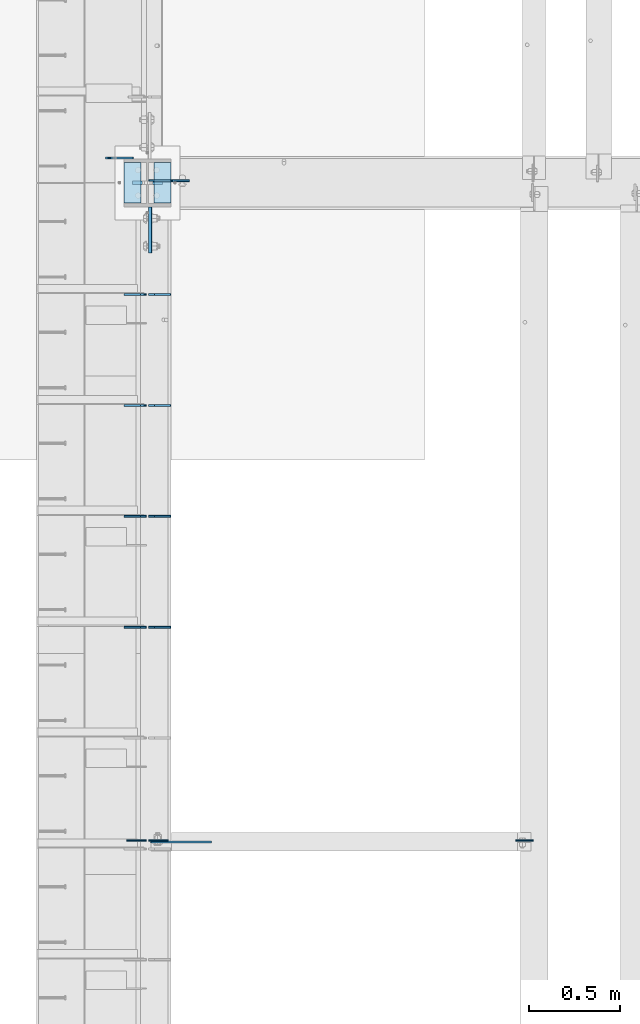
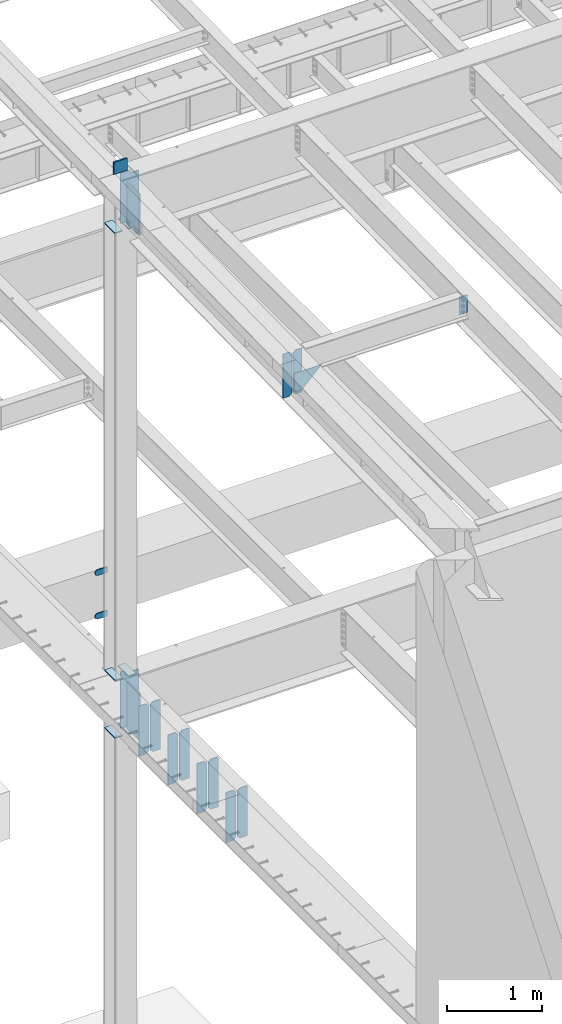
# One storey, part 1518 of 1763: 25 plates, 5 elements without a shape of their own.
"""IFC2X3 building model written with IfcOpenShell, lengths in millimetres."""

from ifc_helpers import new_model, si_unit, frame, origin_with_axes, place, context, subcontext, project, spatial, faceted_brep, material, type_object, element, aggregate, save


model = new_model("IFC2X3")

# Units and contexts
model_context = context("Model", 3, precision=1e-05, world=origin_with_axes())
body_context = subcontext(model_context, "Body", "Model", "MODEL_VIEW")
ifc_project = project(units=[si_unit("LENGTHUNIT", "METRE", prefix="MILLI"), si_unit("AREAUNIT", "SQUARE_METRE"), si_unit("VOLUMEUNIT", "CUBIC_METRE"), si_unit("MASSUNIT", "GRAM", prefix="KILO"), si_unit("TIMEUNIT", "SECOND"), si_unit("PLANEANGLEUNIT", "RADIAN"), si_unit("SOLIDANGLEUNIT", "STERADIAN"), si_unit("THERMODYNAMICTEMPERATUREUNIT", "DEGREE_CELSIUS"), si_unit("LUMINOUSINTENSITYUNIT", "LUMEN")], contexts=[model_context])

# Site, building, storey
site_placement = place(None, origin_with_axes())
site = spatial("IfcSite", under=ifc_project, at=site_placement, CompositionType="ELEMENT")
building_placement = place(site_placement, origin_with_axes())
building = spatial("IfcBuilding", under=site, at=building_placement, Name="Undefined", CompositionType="ELEMENT")
storey_placement = place(building_placement, origin_with_axes())
storey = spatial("IfcBuildingStorey", under=building, at=storey_placement, Name="Undefined", CompositionType="ELEMENT", Elevation=0.0)

# Assembly, plates
assembly_1_placement = place(storey_placement, origin_with_axes())
assembly_1 = element("IfcElementAssembly", 1, at=assembly_1_placement, inside=storey, Name="COLUMN", AssemblyPlace="NOTDEFINED", PredefinedType="RIGID_FRAME")
ifc_material_1 = material(Name="STEEL/A36")
plate_type_1 = type_object("IfcPlateType", PredefinedType="NOTDEFINED")
plate_1_placement = place(assembly_1_placement, frame((-87453.2247736983, 44942.125, 6489.69999847412), z_axis=(0.0, 0.0, -1.0), x_axis=(-1.0, 0.0, 0.0)))
plate_1 = element("IfcPlate", 2, at=plate_1_placement, type_object=plate_type_1, material=ifc_material_1, Name="PLATE", context=body_context, shape_type="Brep", body=[
    faceted_brep([(0.0, -4.76249999999982, 0.0), (0.0, -4.76250000000073, 76.1999969482422), (0.0, 4.76250000000073, 76.1999969482422), (0.0, 4.76249999999982, 0.0), (114.299995422363, -4.76250000000073, 76.1999969482422), (114.299995422363, 4.76250000000073, 76.1999969482422), (126.073542436527, -4.76250000000073, 74.3352502937696), (126.073542436527, 4.76250000000073, 74.3352502937696), (136.694612637817, -4.76250000000073, 68.923544725345), (136.694612637817, 4.76250000000073, 68.923544725345), (145.123541673587, -4.76250000000073, 60.4946156895749), (145.123541673587, 4.76250000000073, 60.4946156895749), (150.535247242013, -4.76250000000073, 49.8735454882844), (150.535247242013, 4.76250000000073, 49.8735454882844), (152.399993896484, -4.76250000000073, 38.0999984741211), (152.399993896484, 4.76250000000073, 38.0999984741211), (150.535247242013, -4.76250000000073, 26.3264514599578), (150.535247242013, 4.76250000000073, 26.3264514599578), (145.123541673587, -4.76250000000073, 15.7053812586673), (145.123541673587, 4.76250000000073, 15.7053812586673), (136.694612637817, -4.76250000000073, 7.27645222289721), (136.694612637817, 4.76250000000073, 7.27645222289721), (126.073542436527, -4.76250000000073, 1.86474665447258), (126.073542436527, 4.76250000000073, 1.86474665447258), (114.299995422363, -4.76250000000073, 0.0), (114.299995422363, 4.76250000000073, 0.0)], [[[0, 1, 2, 3]], [[1, 4, 5, 2]], [[4, 6, 7, 5]], [[6, 8, 9, 7]], [[8, 10, 11, 9]], [[10, 12, 13, 11]], [[12, 14, 15, 13]], [[14, 16, 17, 15]], [[16, 18, 19, 17]], [[18, 20, 21, 19]], [[20, 22, 23, 21]], [[22, 24, 25, 23]], [[24, 0, 3, 25]], [[5, 7, 9, 11, 13, 15, 17, 19, 21, 23, 25, 3, 2]], [[24, 22, 20, 18, 16, 14, 12, 10, 8, 6, 4, 1, 0]]]),
])
plate_2_placement = place(assembly_1_placement, frame((-87453.2247736983, 44942.125, 5930.89999847412), z_axis=(0.0, 0.0, -1.0), x_axis=(-1.0, 0.0, 0.0)))
plate_2 = element("IfcPlate", 3, at=plate_2_placement, type_object=plate_type_1, material=ifc_material_1, Name="PLATE", context=body_context, shape_type="Brep", body=[
    faceted_brep([(0.0, -4.76249999999982, 0.0), (0.0, -4.76250000000073, 76.1999969482422), (0.0, 4.76250000000073, 76.1999969482422), (0.0, 4.76249999999982, 0.0), (114.299995422363, -4.76250000000073, 76.1999969482422), (114.299995422363, 4.76250000000073, 76.1999969482422), (126.073542436527, -4.76250000000073, 74.3352502937696), (126.073542436527, 4.76250000000073, 74.3352502937696), (136.694612637817, -4.76250000000073, 68.923544725345), (136.694612637817, 4.76250000000073, 68.923544725345), (145.123541673587, -4.76250000000073, 60.4946156895749), (145.123541673587, 4.76250000000073, 60.4946156895749), (150.535247242013, -4.76250000000073, 49.8735454882844), (150.535247242013, 4.76250000000073, 49.8735454882844), (152.399993896484, -4.76250000000073, 38.0999984741211), (152.399993896484, 4.76250000000073, 38.0999984741211), (150.535247242013, -4.76250000000073, 26.3264514599578), (150.535247242013, 4.76250000000073, 26.3264514599578), (145.123541673587, -4.76250000000073, 15.7053812586673), (145.123541673587, 4.76250000000073, 15.7053812586673), (136.694612637817, -4.76250000000073, 7.27645222289721), (136.694612637817, 4.76250000000073, 7.27645222289721), (126.073542436527, -4.76250000000073, 1.86474665447258), (126.073542436527, 4.76250000000073, 1.86474665447258), (114.299995422363, -4.76250000000073, 0.0), (114.299995422363, 4.76250000000073, 0.0)], [[[0, 1, 2, 3]], [[1, 4, 5, 2]], [[4, 6, 7, 5]], [[6, 8, 9, 7]], [[8, 10, 11, 9]], [[10, 12, 13, 11]], [[12, 14, 15, 13]], [[14, 16, 17, 15]], [[16, 18, 19, 17]], [[18, 20, 21, 19]], [[20, 22, 23, 21]], [[22, 24, 25, 23]], [[24, 0, 3, 25]], [[5, 7, 9, 11, 13, 15, 17, 19, 21, 23, 25, 3, 2]], [[24, 22, 20, 18, 16, 14, 12, 10, 8, 6, 4, 1, 0]]]),
])

assembly_2_placement = place(storey_placement, origin_with_axes())
assembly_2 = element("IfcElementAssembly", 4, at=assembly_2_placement, inside=storey, Name="BEAM", AssemblyPlace="NOTDEFINED", PredefinedType="RIGID_FRAME")
plate_type_2 = type_object("IfcPlateType", PredefinedType="NOTDEFINED")
plate_3_placement = place(assembly_2_placement, frame((-87246.8497736984, 42362.4375, 4525.9625), z_axis=(0.0, 0.0, 1.0), x_axis=(-1.0, 0.0, 0.0)))
plate_3 = element("IfcPlate", 5, at=plate_3_placement, type_object=plate_type_2, material=ifc_material_1, Name="PLATE", context=body_context, shape_type="Brep", body=[
    faceted_brep([(0.0, -4.76249999999982, 0.0), (0.0, -4.76250000000073, 644.525024414062), (0.0, 4.76250000000073, 644.525024414062), (0.0, 4.76249999999982, 0.0), (89.6937484741211, -4.76250000000073, 644.525024414062), (89.6937484741211, 4.76250000000073, 644.525024414062), (121.443748474121, -4.76250000000073, 612.775024414062), (121.443748474121, 4.76250000000073, 612.775024414062), (121.443748474121, -4.76250000000073, 31.75), (121.443748474121, 4.76250000000073, 31.75), (89.6937484741211, -4.76249999999709, 0.0), (89.6937484741211, 4.76249999999709, 0.0)], [[[0, 1, 2, 3]], [[1, 4, 5, 2]], [[4, 6, 7, 5]], [[6, 8, 9, 7]], [[8, 10, 11, 9]], [[10, 0, 3, 11]], [[5, 7, 9, 11, 3, 2]], [[10, 8, 6, 4, 1, 0]]]),
])
plate_4_placement = place(assembly_2_placement, frame((-87382.5810236984, 42362.4375, 4525.9625), z_axis=(0.0, 0.0, 1.0), x_axis=(-1.0, 0.0, 0.0)))
plate_4 = element("IfcPlate", 6, at=plate_4_placement, type_object=plate_type_2, material=ifc_material_1, Name="PLATE", context=body_context, shape_type="Brep", body=[
    faceted_brep([(0.0, -4.76250000000073, 31.75), (0.0, -4.76250000000073, 612.775024414062), (0.0, 4.76250000000073, 612.775024414062), (0.0, 4.76250000000073, 31.75), (31.75, -4.76250000000073, 644.525024414062), (31.75, 4.76250000000073, 644.525024414062), (121.443748474121, -4.76250000000073, 644.525024414062), (121.443748474121, 4.76250000000073, 644.525024414062), (121.443748474121, -4.76250000000073, 0.0), (121.443748474121, 4.76250000000073, 0.0), (31.75, -4.76250000000073, 0.0), (31.75, 4.76250000000073, 0.0)], [[[0, 1, 2, 3]], [[1, 4, 5, 2]], [[4, 6, 7, 5]], [[6, 8, 9, 7]], [[8, 10, 11, 9]], [[10, 0, 3, 11]], [[5, 7, 9, 11, 3, 2]], [[10, 8, 6, 4, 1, 0]]]),
])
plate_5_placement = place(assembly_2_placement, frame((-87246.8497736984, 42972.0375, 4525.9625), z_axis=(0.0, 0.0, 1.0), x_axis=(-1.0, 0.0, 0.0)))
plate_5 = element("IfcPlate", 7, at=plate_5_placement, type_object=plate_type_2, material=ifc_material_1, Name="PLATE", context=body_context, shape_type="Brep", body=[
    faceted_brep([(0.0, -4.76249999999982, 0.0), (0.0, -4.76250000000073, 644.525024414062), (0.0, 4.76250000000073, 644.525024414062), (0.0, 4.76249999999982, 0.0), (89.6937484741211, -4.76250000000073, 644.525024414062), (89.6937484741211, 4.76250000000073, 644.525024414062), (121.443748474121, -4.76250000000073, 612.775024414062), (121.443748474121, 4.76250000000073, 612.775024414062), (121.443748474121, -4.76250000000073, 31.75), (121.443748474121, 4.76250000000073, 31.75), (89.6937484741211, -4.76249999999709, 0.0), (89.6937484741211, 4.76249999999709, 0.0)], [[[0, 1, 2, 3]], [[1, 4, 5, 2]], [[4, 6, 7, 5]], [[6, 8, 9, 7]], [[8, 10, 11, 9]], [[10, 0, 3, 11]], [[5, 7, 9, 11, 3, 2]], [[10, 8, 6, 4, 1, 0]]]),
])
plate_6_placement = place(assembly_2_placement, frame((-87382.5810236984, 42972.0375, 4525.9625), z_axis=(0.0, 0.0, 1.0), x_axis=(-1.0, 0.0, 0.0)))
plate_6 = element("IfcPlate", 8, at=plate_6_placement, type_object=plate_type_2, material=ifc_material_1, Name="PLATE", context=body_context, shape_type="Brep", body=[
    faceted_brep([(0.0, -4.76250000000073, 31.75), (0.0, -4.76250000000073, 612.775024414062), (0.0, 4.76250000000073, 612.775024414062), (0.0, 4.76250000000073, 31.75), (31.75, -4.76250000000073, 644.525024414062), (31.75, 4.76250000000073, 644.525024414062), (121.443748474121, -4.76250000000073, 644.525024414062), (121.443748474121, 4.76250000000073, 644.525024414062), (121.443748474121, -4.76250000000073, 0.0), (121.443748474121, 4.76250000000073, 0.0), (31.75, -4.76250000000073, 0.0), (31.75, 4.76250000000073, 0.0)], [[[0, 1, 2, 3]], [[1, 4, 5, 2]], [[4, 6, 7, 5]], [[6, 8, 9, 7]], [[8, 10, 11, 9]], [[10, 0, 3, 11]], [[5, 7, 9, 11, 3, 2]], [[10, 8, 6, 4, 1, 0]]]),
])
plate_7_placement = place(assembly_2_placement, frame((-87246.8497736984, 43581.6375, 4525.9625), z_axis=(0.0, 0.0, 1.0), x_axis=(-1.0, 0.0, 0.0)))
plate_7 = element("IfcPlate", 9, at=plate_7_placement, type_object=plate_type_2, material=ifc_material_1, Name="PLATE", context=body_context, shape_type="Brep", body=[
    faceted_brep([(0.0, -4.76249999999982, 0.0), (0.0, -4.76250000000073, 644.525024414062), (0.0, 4.76250000000073, 644.525024414062), (0.0, 4.76249999999982, 0.0), (89.6937484741211, -4.76250000000073, 644.525024414062), (89.6937484741211, 4.76250000000073, 644.525024414062), (121.443748474121, -4.76250000000073, 612.775024414062), (121.443748474121, 4.76250000000073, 612.775024414062), (121.443748474121, -4.76250000000073, 31.75), (121.443748474121, 4.76250000000073, 31.75), (89.6937484741211, -4.76249999999709, 0.0), (89.6937484741211, 4.76249999999709, 0.0)], [[[0, 1, 2, 3]], [[1, 4, 5, 2]], [[4, 6, 7, 5]], [[6, 8, 9, 7]], [[8, 10, 11, 9]], [[10, 0, 3, 11]], [[5, 7, 9, 11, 3, 2]], [[10, 8, 6, 4, 1, 0]]]),
])
plate_8_placement = place(assembly_2_placement, frame((-87382.5810236984, 43581.6375, 4525.9625), z_axis=(0.0, 0.0, 1.0), x_axis=(-1.0, 0.0, 0.0)))
plate_8 = element("IfcPlate", 10, at=plate_8_placement, type_object=plate_type_2, material=ifc_material_1, Name="PLATE", context=body_context, shape_type="Brep", body=[
    faceted_brep([(0.0, -4.76250000000073, 31.75), (0.0, -4.76250000000073, 612.775024414062), (0.0, 4.76250000000073, 612.775024414062), (0.0, 4.76250000000073, 31.75), (31.75, -4.76250000000073, 644.525024414062), (31.75, 4.76250000000073, 644.525024414062), (121.443748474121, -4.76250000000073, 644.525024414062), (121.443748474121, 4.76250000000073, 644.525024414062), (121.443748474121, -4.76250000000073, 0.0), (121.443748474121, 4.76250000000073, 0.0), (31.75, -4.76250000000073, 0.0), (31.75, 4.76250000000073, 0.0)], [[[0, 1, 2, 3]], [[1, 4, 5, 2]], [[4, 6, 7, 5]], [[6, 8, 9, 7]], [[8, 10, 11, 9]], [[10, 0, 3, 11]], [[5, 7, 9, 11, 3, 2]], [[10, 8, 6, 4, 1, 0]]]),
])
plate_9_placement = place(assembly_2_placement, frame((-87246.8497736984, 44191.2375, 4525.9625), z_axis=(0.0, 0.0, 1.0), x_axis=(-1.0, 0.0, 0.0)))
plate_9 = element("IfcPlate", 11, at=plate_9_placement, type_object=plate_type_2, material=ifc_material_1, Name="PLATE", context=body_context, shape_type="Brep", body=[
    faceted_brep([(0.0, -4.76249999999982, 0.0), (0.0, -4.76250000000073, 644.525024414062), (0.0, 4.76250000000073, 644.525024414062), (0.0, 4.76249999999982, 0.0), (89.6937484741211, -4.76250000000073, 644.525024414062), (89.6937484741211, 4.76250000000073, 644.525024414062), (121.443748474121, -4.76250000000073, 612.775024414062), (121.443748474121, 4.76250000000073, 612.775024414062), (121.443748474121, -4.76250000000073, 31.75), (121.443748474121, 4.76250000000073, 31.75), (89.6937484741211, -4.76249999999709, 0.0), (89.6937484741211, 4.76249999999709, 0.0)], [[[0, 1, 2, 3]], [[1, 4, 5, 2]], [[4, 6, 7, 5]], [[6, 8, 9, 7]], [[8, 10, 11, 9]], [[10, 0, 3, 11]], [[5, 7, 9, 11, 3, 2]], [[10, 8, 6, 4, 1, 0]]]),
])
plate_10_placement = place(assembly_2_placement, frame((-87382.5810236984, 44191.2375, 4525.9625), z_axis=(0.0, 0.0, 1.0), x_axis=(-1.0, 0.0, 0.0)))
plate_10 = element("IfcPlate", 12, at=plate_10_placement, type_object=plate_type_2, material=ifc_material_1, Name="PLATE", context=body_context, shape_type="Brep", body=[
    faceted_brep([(0.0, -4.76250000000073, 31.75), (0.0, -4.76250000000073, 612.775024414062), (0.0, 4.76250000000073, 612.775024414062), (0.0, 4.76250000000073, 31.75), (31.75, -4.76250000000073, 644.525024414062), (31.75, 4.76250000000073, 644.525024414062), (121.443748474121, -4.76250000000073, 644.525024414062), (121.443748474121, 4.76250000000073, 644.525024414062), (121.443748474121, -4.76250000000073, 0.0), (121.443748474121, 4.76250000000073, 0.0), (31.75, -4.76250000000073, 0.0), (31.75, 4.76250000000073, 0.0)], [[[0, 1, 2, 3]], [[1, 4, 5, 2]], [[4, 6, 7, 5]], [[6, 8, 9, 7]], [[8, 10, 11, 9]], [[10, 0, 3, 11]], [[5, 7, 9, 11, 3, 2]], [[10, 8, 6, 4, 1, 0]]]),
])
aggregate(assembly_2, [plate_3, plate_4, plate_5, plate_6, plate_7, plate_8, plate_9, plate_10])

# Plate
ifc_material_2 = material(Name="STEEL/A572-50")
plate_type_3 = type_object("IfcPlateType", PredefinedType="NOTDEFINED")
plate_11_placement = place(assembly_1_placement, frame((-87292.8872721725, 44805.5999999732, 11760.2588348652), z_axis=(0.0, 0.0, -1.0), x_axis=(-1.0, 0.0, 0.0)))
plate_11 = element("IfcPlate", 13, at=plate_11_placement, type_object=plate_type_3, material=ifc_material_2, Name="PLATE", context=body_context, shape_type="Brep", body=[
    faceted_brep([(7.27595761418343e-12, 9.52500000000146, 155.574990844727), (-1.45519152283669e-11, 7.27595761418343e-12, 165.099990844727), (165.099990844727, 0.0, 165.099990844727), (165.099990844727, 9.52500000000146, 155.574990844727), (-3.63797880709171e-11, -9.5249999999869, 155.574990844727), (165.099990844727, -9.52500000000146, 155.574990844727), (0.0, 9.52500000000146, 0.0), (0.0, -9.52500000000146, 0.0), (165.099990844727, -9.52500000000146, 0.0), (165.099990844727, 9.52500000000146, 0.0)], [[[0, 1, 2, 3]], [[1, 4, 5, 2]], [[6, 7, 4, 1, 0]], [[5, 8, 9, 3, 2]], [[8, 7, 6, 9]], [[9, 6, 0, 3]], [[7, 8, 5, 4]]]),
])

plate_type_4 = type_object("IfcPlateType", PredefinedType="NOTDEFINED")
plate_12_placement = place(assembly_1_placement, frame((-87410.3622736983, 44694.475, 4451.34997558594), z_axis=(0.0, 1.0, 0.0), x_axis=(-1.0, 0.0, 0.0)))
plate_12 = element("IfcPlate", 14, at=plate_12_placement, type_object=plate_type_4, material=ifc_material_1, Name="PLATE", context=body_context, shape_type="Brep", body=[
    faceted_brep([(0.0, -6.34999999999491, 1.45519152283669e-11), (0.0, -6.35000000000036, 222.25), (0.0, 6.35000000000036, 222.25), (0.0, 6.34999999999491, -2.91038304567337e-11), (93.6624984741211, -6.35000000000036, 222.25), (93.6624984741211, 6.35000000000036, 222.25), (93.6624984741211, -6.35000000000036, 0.0), (93.6624984741211, 6.35000000000036, 0.0)], [[[0, 1, 2, 3]], [[1, 4, 5, 2]], [[4, 6, 7, 5]], [[6, 0, 3, 7]], [[5, 7, 3, 2]], [[6, 4, 1, 0]]]),
])

plate_13_placement = place(assembly_1_placement, frame((-87410.3622736983, 44694.475, 5187.95), z_axis=(0.0, 1.0, 0.0), x_axis=(-1.0, 0.0, 0.0)))
plate_13 = element("IfcPlate", 15, at=plate_13_placement, type_object=plate_type_4, material=ifc_material_1, Name="PLATE", context=body_context, shape_type="Brep", body=[
    faceted_brep([(0.0, -6.34999999999491, 1.45519152283669e-11), (0.0, -6.35000000000036, 222.25), (0.0, 6.35000000000036, 222.25), (0.0, 6.34999999999491, -2.91038304567337e-11), (93.6624984741211, -6.35000000000036, 222.25), (93.6624984741211, 6.35000000000036, 222.25), (93.6624984741211, -6.35000000000036, 0.0), (93.6624984741211, 6.35000000000036, 0.0)], [[[0, 1, 2, 3]], [[1, 4, 5, 2]], [[4, 6, 7, 5]], [[6, 0, 3, 7]], [[5, 7, 3, 2]], [[6, 4, 1, 0]]]),
])

plate_14_placement = place(assembly_1_placement, frame((-87410.3622736983, 44694.475, 10928.4088287617), z_axis=(0.0, 1.0, 0.0), x_axis=(-1.0, 0.0, 0.0)))
plate_14 = element("IfcPlate", 16, at=plate_14_placement, type_object=plate_type_4, material=ifc_material_1, Name="PLATE", context=body_context, shape_type="Brep", body=[
    faceted_brep([(0.0, -6.34999999999491, 1.45519152283669e-11), (0.0, -6.35000000000036, 222.25), (0.0, 6.35000000000036, 222.25), (0.0, 6.34999999999491, -2.91038304567337e-11), (93.6624984741211, -6.35000000000036, 222.25), (93.6624984741211, 6.35000000000036, 222.25), (93.6624984741211, -6.35000000000036, 0.0), (93.6624984741211, 6.35000000000036, 0.0)], [[[0, 1, 2, 3]], [[1, 4, 5, 2]], [[4, 6, 7, 5]], [[6, 0, 3, 7]], [[5, 7, 3, 2]], [[6, 4, 1, 0]]]),
])

plate_15_placement = place(assembly_1_placement, frame((-87246.8497736983, 44694.475, 10928.4088287617), z_axis=(0.0, 1.0, 0.0), x_axis=(-1.0, 0.0, 0.0)))
plate_15 = element("IfcPlate", 17, at=plate_15_placement, type_object=plate_type_4, material=ifc_material_1, Name="PLATE", context=body_context, shape_type="Brep", body=[
    faceted_brep([(0.0, -6.34999999999491, 1.45519152283669e-11), (0.0, -6.35000000000036, 222.25), (0.0, 6.35000000000036, 222.25), (0.0, 6.34999999999491, -2.91038304567337e-11), (93.6624984741211, -6.35000000000036, 222.25), (93.6624984741211, 6.35000000000036, 222.25), (93.6624984741211, -6.35000000000036, 0.0), (93.6624984741211, 6.35000000000036, 0.0)], [[[0, 1, 2, 3]], [[1, 4, 5, 2]], [[4, 6, 7, 5]], [[6, 0, 3, 7]], [[5, 7, 3, 2]], [[6, 4, 1, 0]]]),
])

plate_16_placement = place(assembly_1_placement, frame((-87246.8497736983, 44694.475, 4451.34997558594), z_axis=(0.0, 1.0, 0.0), x_axis=(-1.0, 0.0, 0.0)))
plate_16 = element("IfcPlate", 18, at=plate_16_placement, type_object=plate_type_4, material=ifc_material_1, Name="PLATE", context=body_context, shape_type="Brep", body=[
    faceted_brep([(0.0, -6.34999999999491, 1.45519152283669e-11), (0.0, -6.35000000000036, 222.25), (0.0, 6.35000000000036, 222.25), (0.0, 6.34999999999491, -2.91038304567337e-11), (93.6624984741211, -6.35000000000036, 222.25), (93.6624984741211, 6.35000000000036, 222.25), (93.6624984741211, -6.35000000000036, 0.0), (93.6624984741211, 6.35000000000036, 0.0)], [[[0, 1, 2, 3]], [[1, 4, 5, 2]], [[4, 6, 7, 5]], [[6, 0, 3, 7]], [[5, 7, 3, 2]], [[6, 4, 1, 0]]]),
])

plate_17_placement = place(assembly_1_placement, frame((-87246.8497736983, 44694.475, 5187.95), z_axis=(0.0, 1.0, 0.0), x_axis=(-1.0, 0.0, 0.0)))
plate_17 = element("IfcPlate", 19, at=plate_17_placement, type_object=plate_type_4, material=ifc_material_1, Name="PLATE", context=body_context, shape_type="Brep", body=[
    faceted_brep([(0.0, -6.34999999999491, 1.45519152283669e-11), (0.0, -6.35000000000036, 222.25), (0.0, 6.35000000000036, 222.25), (0.0, 6.34999999999491, -2.91038304567337e-11), (93.6624984741211, -6.35000000000036, 222.25), (93.6624984741211, 6.35000000000036, 222.25), (93.6624984741211, -6.35000000000036, 0.0), (93.6624984741211, 6.35000000000036, 0.0)], [[[0, 1, 2, 3]], [[1, 4, 5, 2]], [[4, 6, 7, 5]], [[6, 0, 3, 7]], [[5, 7, 3, 2]], [[6, 4, 1, 0]]]),
])

# Assembly, plate
assembly_3_placement = place(storey_placement, origin_with_axes())
assembly_3 = element("IfcElementAssembly", 20, at=assembly_3_placement, inside=storey, Name="BEAM", AssemblyPlace="NOTDEFINED", PredefinedType="RIGID_FRAME")
plate_type_5 = type_object("IfcPlateType", PredefinedType="NOTDEFINED")
plate_18_placement = place(assembly_3_placement, frame((-85253.0631665555, 41189.2749999833, 11483.0991337623), z_axis=(-1.0, 0.0, 0.0), x_axis=(0.0, 0.0, -1.0)))
plate_18 = element("IfcPlate", 21, at=plate_18_placement, type_object=plate_type_5, material=ifc_material_1, Name="PLATE", context=body_context, shape_type="Brep", body=[
    faceted_brep([(1.81898940354586e-12, -3.17500000000291, 0.0), (-2.52839527092874e-10, -3.17500000000001, 98.4250000002357), (4.17785486206412e-08, 3.17500000000001, 98.425000000243), (-1.81898940354586e-12, 3.17499999997381, 0.0), (228.600006103516, -3.17499999999927, 98.4250030517578), (228.600006103516, 3.17499999999927, 98.4250030517578), (228.600006103516, -3.17500000001019, -7.27595761418343e-12), (228.600006103516, 3.17499999999563, -7.27595761418343e-12)], [[[0, 1, 2, 3]], [[1, 4, 5, 2]], [[4, 6, 7, 5]], [[6, 0, 3, 7]], [[5, 7, 3, 2]], [[6, 4, 1, 0]]]),
])
aggregate(assembly_3, [plate_18])

# Plate
plate_type_6 = type_object("IfcPlateType", PredefinedType="NOTDEFINED")
plate_19_placement = place(assembly_1_placement, frame((-87358.7685236984, 44673.8375, 5143.5), z_axis=(0.0, -1.0, 0.0), x_axis=(0.0, 0.0, -1.0)))
plate_19 = element("IfcPlate", 22, at=plate_19_placement, type_object=plate_type_6, material=ifc_material_2, Name="PLATE", context=body_context, shape_type="Brep", body=[
    faceted_brep([(0.0, -9.52500000000146, 0.0), (1.13504938781261e-09, -9.52499999999964, 254.000000000065), (1.13504938781261e-09, 9.52499999999964, 254.000000000065), (0.0, 9.52500000000146, 0.0), (609.599975585938, -9.52499999999418, 254.0), (609.599975585938, 9.52499999999418, 254.0), (609.599975585938, -9.52499999999418, 0.0), (609.599975585938, 9.52499999999418, 0.0)], [[[0, 1, 2, 3]], [[1, 4, 5, 2]], [[4, 6, 7, 5]], [[6, 0, 3, 7]], [[5, 7, 3, 2]], [[6, 4, 1, 0]]]),
])

# Assembly, plate
assembly_4_placement = place(storey_placement, origin_with_axes())
assembly_4 = element("IfcElementAssembly", 23, at=assembly_4_placement, inside=storey, Name="BEAM", AssemblyPlace="NOTDEFINED", PredefinedType="RIGID_FRAME")
plate_type_7 = type_object("IfcPlateType", PredefinedType="NOTDEFINED")
plate_20_placement = place(assembly_4_placement, frame((-87260.0435256352, 41181.3375080699, 10973.9155048644), z_axis=(-0.707106781186552, 0.0, 0.707106781186543), x_axis=(0.707106781186542, 0.0, 0.707106781186553)))
plate_20 = element("IfcPlate", 24, at=plate_20_placement, type_object=plate_type_7, material=ifc_material_1, Name="PLATE", context=body_context, shape_type="Brep", body=[
    faceted_brep([(0.0, -4.76249999999982, 0.0), (-68.6865768438074, -4.76249999999709, 68.6865844732238), (-68.6865768438074, 4.76249999999709, 68.6865844732238), (0.0, 4.76249999999982, 0.0), (98.2851104731089, -4.76249999999709, 235.658279419542), (98.2851104731089, 4.76249999999709, 235.658279419542), (333.943389893917, -4.76249999999709, -3.92901711165905e-10), (333.943389893917, 4.76249999999709, -3.92901711165905e-10)], [[[0, 1, 2, 3]], [[1, 4, 5, 2]], [[4, 6, 7, 5]], [[6, 0, 3, 7]], [[5, 7, 3, 2]], [[6, 4, 1, 0]]]),
])
aggregate(assembly_4, [plate_20])

# Assembly, plates
assembly_5_placement = place(storey_placement, origin_with_axes())
assembly_5 = element("IfcElementAssembly", 25, at=assembly_5_placement, inside=storey, Name="BEAM", AssemblyPlace="NOTDEFINED", PredefinedType="RIGID_FRAME")
plate_type_8 = type_object("IfcPlateType", PredefinedType="NOTDEFINED")
plate_21_placement = place(assembly_5_placement, frame((-87381.2935236983, 41189.2749999013, 10934.1951600328), z_axis=(0.0, 0.0, 1.0), x_axis=(-1.0, 0.0, 0.0)))
plate_21 = element("IfcPlate", 26, at=plate_21_placement, type_object=plate_type_8, material=ifc_material_1, Name="PLATE", context=body_context, shape_type="Brep", body=[
    faceted_brep([(0.0, -3.17500000000291, 31.75), (0.0, -3.17500000000291, 535.965942382812), (0.0, 3.17500000000291, 535.965942382812), (0.0, 3.17500000000291, 31.75), (31.75, -3.17500000000291, 567.715942382812), (31.75, 3.17500000000291, 567.715942382812), (108.743751525879, -3.17500000000291, 567.715942382812), (108.743751525879, 3.17500000000291, 567.715942382812), (108.743751525879, -3.17500000000291, 0.0), (108.743751525879, 3.17500000000291, 0.0), (31.7499999999036, -3.17499999997381, 9.42916855706244e-11), (31.7499999998854, 3.17500000000291, 9.42916855706244e-11)], [[[0, 1, 2, 3]], [[1, 4, 5, 2]], [[4, 6, 7, 5]], [[6, 8, 9, 7]], [[8, 10, 11, 9]], [[10, 0, 3, 11]], [[5, 7, 9, 11, 3, 2]], [[10, 8, 6, 4, 1, 0]]]),
])
plate_22_placement = place(assembly_5_placement, frame((-87369.5810236984, 41189.2750000394, 10934.1951600356), z_axis=(0.0, 0.0, 1.0), x_axis=(1.0, 0.0, 0.0)))
plate_22 = element("IfcPlate", 27, at=plate_22_placement, type_object=plate_type_8, material=ifc_material_1, Name="PLATE", context=body_context, shape_type="Brep", body=[
    faceted_brep([(0.0, -3.17500000000291, 31.75), (0.0, -3.17500000000291, 537.553405761719), (0.0, 3.17500000000291, 537.553405761719), (0.0, 3.17500000000291, 31.75), (31.75, -3.17500000000291, 569.303405761719), (31.75, 3.17500000000291, 569.303405761719), (109.537498474121, -3.17500000000291, 569.303405761719), (109.537498474121, 3.17500000000291, 569.303405761719), (109.537498474121, -3.17500000000291, 0.0), (109.537498474121, 3.17500000000291, 0.0), (31.7499999999036, -3.17499999997381, 9.42916855706244e-11), (31.7499999998854, 3.17500000000291, 9.42916855706244e-11)], [[[0, 1, 2, 3]], [[1, 4, 5, 2]], [[4, 6, 7, 5]], [[6, 8, 9, 7]], [[8, 10, 11, 9]], [[10, 0, 3, 11]], [[5, 7, 9, 11, 3, 2]], [[10, 8, 6, 4, 1, 0]]]),
])
aggregate(assembly_5, [plate_21, plate_22])

# Plate
plate_type_9 = type_object("IfcPlateType", PredefinedType="NOTDEFINED")
plate_23_placement = place(assembly_1_placement, frame((-87361.9435236984, 44673.8374999996, 11553.994807839), z_axis=(0.0, -1.0, 0.0), x_axis=(0.0, 0.0, -1.0)))
plate_23 = element("IfcPlate", 28, at=plate_23_placement, type_object=plate_type_9, material=ifc_material_2, Name="PLATE", context=body_context, shape_type="Brep", body=[
    faceted_brep([(-7.27595761418343e-12, -7.9375, 0.0), (0.0, -7.9375, 254.0), (0.0, 7.9375, 254.0), (-7.27595761418343e-12, 7.9375, 0.0), (533.400024414062, -7.9375, 254.0), (533.400024414062, 7.9375, 254.0), (533.400024414062, -7.9375, 0.0), (533.400024414062, 7.9375, 0.0)], [[[0, 1, 2, 3]], [[1, 4, 5, 2]], [[4, 6, 7, 5]], [[6, 0, 3, 7]], [[5, 7, 3, 2]], [[6, 4, 1, 0]]]),
])

plate_type_10 = type_object("IfcPlateType", PredefinedType="NOTDEFINED")
plate_24_placement = place(assembly_1_placement, frame((-87369.0872736983, 44816.7124999732, 11582.4588409687), z_axis=(1.0, 0.0, 0.0), x_axis=(0.0, 0.0, -1.0)))
plate_24 = element("IfcPlate", 29, at=plate_24_placement, type_object=plate_type_10, material=ifc_material_1, Name="PLATE", context=body_context, shape_type="Brep", body=[
    faceted_brep([(25.4000001907334, -4.76250000000073, 122.237503051758), (25.4000001907334, 4.76250000000073, 122.237503051758), (-2.5465851649642e-11, 4.76250000019581, 122.237500000236), (-3.45607986673713e-11, -4.76249999983202, 122.23750000025), (30.2600797087798, -4.76250000000073, 123.204232974349), (30.2600797087798, 4.76250000000073, 123.204232974349), (34.3802561769335, -4.76250000000073, 125.957246874823), (34.3802561769335, 4.76250000000073, 125.957246874823), (37.133270077411, -4.76250000000073, 130.077423342977), (37.133270077411, 4.76250000000073, 130.077423342977), (38.0999999999985, -4.76250000000073, 134.937502861023), (38.0999999999985, 4.76250000000073, 134.937502861023), (38.0999999999985, -4.76250000000073, 223.837493896484), (38.0999999999985, 4.76250000000073, 223.837493896484), (647.700012207031, -4.76250000000073, 0.0), (0.0, -4.76249999999982, 0.0), (0.0, 4.76249999999982, 0.0), (647.700012207031, 4.76250000000073, 0.0), (647.700012207031, -4.76250000000073, 223.837493896484), (647.700012207031, 4.76250000000073, 223.837493896484)], [[[0, 1, 2, 3]], [[4, 5, 1, 0]], [[6, 7, 5, 4]], [[8, 9, 7, 6]], [[10, 11, 9, 8]], [[12, 13, 11, 10]], [[14, 15, 16, 17]], [[18, 14, 17, 19]], [[8, 6, 4, 0, 3, 15, 14, 18, 12, 10]], [[16, 15, 3, 2]], [[19, 17, 16, 2, 1, 5, 7, 9, 11, 13]], [[18, 19, 13, 12]]]),
])

plate_25_placement = place(assembly_1_placement, frame((-87369.0872736983, 44817.50625, 5181.6), z_axis=(1.0, 0.0, 0.0), x_axis=(0.0, 0.0, -1.0)))
plate_25 = element("IfcPlate", 30, at=plate_25_placement, type_object=plate_type_10, material=ifc_material_1, Name="PLATE", context=body_context, shape_type="Brep", body=[
    faceted_brep([(25.4000001907334, -4.76250000000073, 122.237503051758), (25.4000001907334, 4.76250000000073, 122.237503051758), (-2.5465851649642e-11, 4.76250000019581, 122.237500000236), (-3.45607986673713e-11, -4.76249999983202, 122.23750000025), (30.2600797087798, -4.76250000000073, 123.204232974349), (30.2600797087798, 4.76250000000073, 123.204232974349), (34.3802561769335, -4.76250000000073, 125.957246874823), (34.3802561769335, 4.76250000000073, 125.957246874823), (37.133270077411, -4.76250000000073, 130.077423342977), (37.133270077411, 4.76250000000073, 130.077423342977), (38.0999999999985, -4.76250000000073, 134.937502861023), (38.0999999999985, 4.76250000000073, 134.937502861023), (38.0999999999985, -4.76250000000073, 223.837493896484), (38.0999999999985, 4.76250000000073, 223.837493896484), (723.900024414062, -4.76250000000073, 0.0), (0.0, -4.76249999999982, 0.0), (0.0, 4.76249999999982, 0.0), (723.900024414062, 4.76250000000073, 0.0), (723.900024414062, -4.76250000000073, 223.837493896484), (723.900024414062, 4.76250000000073, 223.837493896484)], [[[0, 1, 2, 3]], [[4, 5, 1, 0]], [[6, 7, 5, 4]], [[8, 9, 7, 6]], [[10, 11, 9, 8]], [[12, 13, 11, 10]], [[14, 15, 16, 17]], [[18, 14, 17, 19]], [[8, 6, 4, 0, 3, 15, 14, 18, 12, 10]], [[16, 15, 3, 2]], [[19, 17, 16, 2, 1, 5, 7, 9, 11, 13]], [[18, 19, 13, 12]]]),
])

aggregate(assembly_1, [plate_1, plate_2, plate_11, plate_12, plate_13, plate_14, plate_15, plate_24, plate_23, plate_16, plate_17, plate_25, plate_19])

save(model, "model.ifc")
